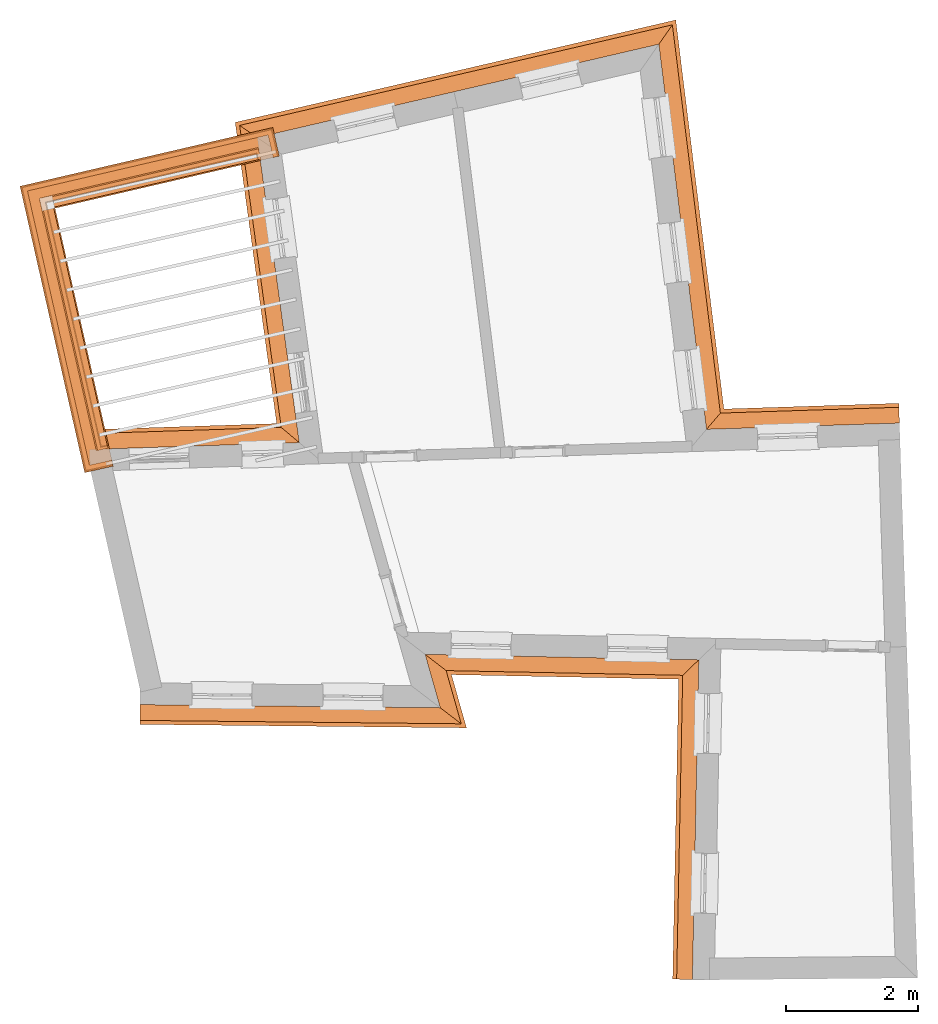
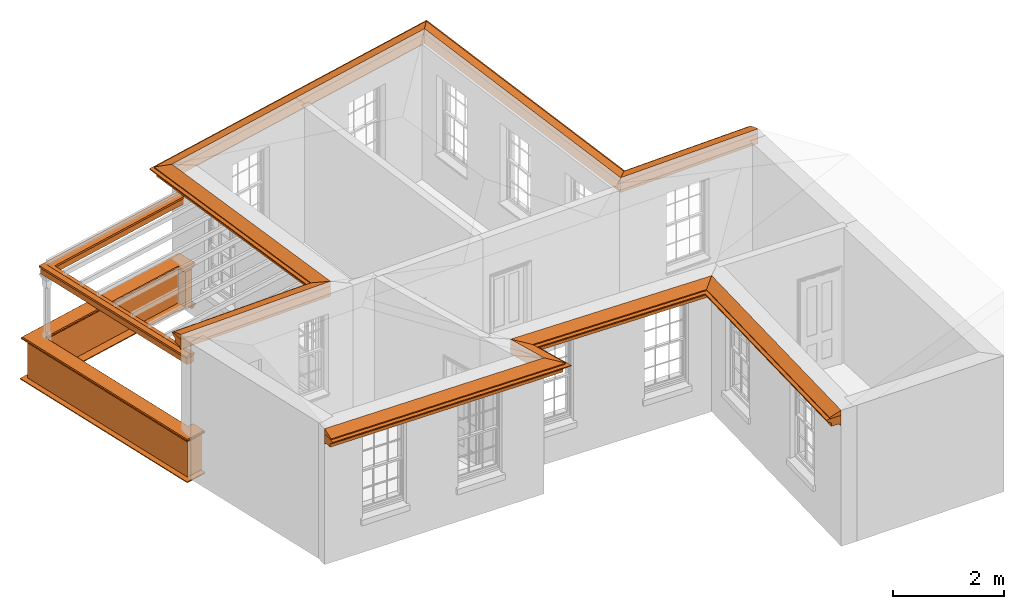
# One storey, part 10 of 11: 9 proxies.
"""IFC2X3 building model written with IfcOpenShell, lengths in metres."""

from ifc_helpers import new_model, entity, si_unit, frame, origin, place, context, subcontext, project, spatial, element, save


model = new_model("IFC2X3")

# Units and contexts
model_context = context("Model", 3, world=origin())
body_context = subcontext(model_context, "Body", "Model", "MODEL_VIEW")
ifc_project = project(units=[si_unit("PLANEANGLEUNIT", "RADIAN"), si_unit("MASSUNIT", "GRAM", prefix="KILO"), si_unit("FORCEUNIT", "NEWTON", prefix="KILO"), si_unit("LENGTHUNIT", "METRE")], contexts=[model_context])

# Site, building, storey
site_placement = place(None, origin())
site = spatial("IfcSite", under=ifc_project, at=site_placement, CompositionType="ELEMENT")
building_placement = place(None, origin())
building = spatial("IfcBuilding", under=site, at=building_placement, Name="Building plot-10", CompositionType="ELEMENT")
storey_placement = place(None, frame((0.0, 0.0, 4.6)))
storey = spatial("IfcBuildingStorey", under=building, at=storey_placement, Name="Floor 1", CompositionType="ELEMENT", Elevation=4.6)

# Proxies
proxy_1_placement = place(storey_placement, frame((0.0, 0.0, 3.0)))
axis2_placement3_d_1 = entity("IfcAxis2Placement3D", entity("IfcCartesianPoint", [0.0, 0.0, 0.0]))
element("IfcBuildingElementProxy", 1, at=proxy_1_placement, inside=storey, Name="eaves", CompositionType="ELEMENT", context=body_context, shape_type="SweptSolid", held_by="IfcProductRepresentation", body=[
    entity("IfcSurfaceCurveSweptAreaSolid", entity("IfcArbitraryClosedProfileDef", "AREA", None, entity("IfcPolyline", [entity("IfcCartesianPoint", [-0.11, 0.25]), entity("IfcCartesianPoint", [-0.33, 0.25]), entity("IfcCartesianPoint", [-0.33, 0.265]), entity("IfcCartesianPoint", [-0.318, 0.268]), entity("IfcCartesianPoint", [-0.309, 0.274]), entity("IfcCartesianPoint", [-0.303, 0.283]), entity("IfcCartesianPoint", [-0.3, 0.295]), entity("IfcCartesianPoint", [-0.285, 0.295]), entity("IfcCartesianPoint", [-0.285, 0.455]), entity("IfcCartesianPoint", [-0.205, 0.455]), entity("IfcCartesianPoint", [-0.205, 0.47]), entity("IfcCartesianPoint", [-0.19, 0.47]), entity("IfcCartesianPoint", [-0.189, 0.483]), entity("IfcCartesianPoint", [-0.186, 0.494]), entity("IfcCartesianPoint", [-0.179, 0.506]), entity("IfcCartesianPoint", [-0.17, 0.514]), entity("IfcCartesianPoint", [-0.16, 0.52]), entity("IfcCartesianPoint", [-0.149, 0.529]), entity("IfcCartesianPoint", [-0.143, 0.539]), entity("IfcCartesianPoint", [-0.14, 0.55]), entity("IfcCartesianPoint", [-0.12, 0.55]), entity("IfcCartesianPoint", [-0.11, 0.48]), entity("IfcCartesianPoint", [-0.11, 0.25])])), axis2_placement3_d_1, entity("IfcPolyline", [entity("IfcCartesianPoint", [42.2025412159909, 16.5029528697415]), entity("IfcCartesianPoint", [46.417501549058, 16.4585722214546]), entity("IfcCartesianPoint", [46.1870677663314, 17.2713951315665]), entity("IfcCartesianPoint", [50.9238235158592, 17.1770031829348]), entity("IfcCartesianPoint", [50.8222805958714, 12.0813989810033])]), 0.0, 1.0, entity("IfcPlane", axis2_placement3_d_1)),
])
proxy_2_placement = place(storey_placement, frame((0.0, 0.0, 3.0)))
axis2_placement3_d_2 = entity("IfcAxis2Placement3D", entity("IfcCartesianPoint", [0.0, 0.0, 0.0]))
element("IfcBuildingElementProxy", 2, at=proxy_2_placement, inside=storey, Name="eaves", CompositionType="ELEMENT", context=body_context, shape_type="SweptSolid", held_by="IfcProductRepresentation", body=[
    entity("IfcSurfaceCurveSweptAreaSolid", entity("IfcArbitraryClosedProfileDef", "AREA", None, entity("IfcPolyline", [entity("IfcCartesianPoint", [-0.11, 0.25]), entity("IfcCartesianPoint", [-0.11, 0.48]), entity("IfcCartesianPoint", [-0.08, 0.49]), entity("IfcCartesianPoint", [0.0, 0.25]), entity("IfcCartesianPoint", [-0.11, 0.25])])), axis2_placement3_d_2, entity("IfcPolyline", [entity("IfcCartesianPoint", [42.2025412159909, 16.5029528697415]), entity("IfcCartesianPoint", [46.417501549058, 16.4585722214546]), entity("IfcCartesianPoint", [46.1870677663314, 17.2713951315665]), entity("IfcCartesianPoint", [50.9238235158592, 17.1770031829348]), entity("IfcCartesianPoint", [50.8222805958714, 12.0813989810033])]), 0.0, 1.0, entity("IfcPlane", axis2_placement3_d_2)),
])
proxy_3_placement = place(storey_placement, frame((0.0, 0.0, 3.0)))
axis2_placement3_d_3 = entity("IfcAxis2Placement3D", entity("IfcCartesianPoint", [0.0, 0.0, 0.0]))
element("IfcBuildingElementProxy", 3, at=proxy_3_placement, inside=storey, Name="eaves", CompositionType="ELEMENT", context=body_context, shape_type="SweptSolid", held_by="IfcProductRepresentation", body=[
    entity("IfcSurfaceCurveSweptAreaSolid", entity("IfcArbitraryClosedProfileDef", "AREA", None, entity("IfcPolyline", [entity("IfcCartesianPoint", [-0.11, 0.25]), entity("IfcCartesianPoint", [-0.33, 0.25]), entity("IfcCartesianPoint", [-0.33, 0.265]), entity("IfcCartesianPoint", [-0.318, 0.268]), entity("IfcCartesianPoint", [-0.309, 0.274]), entity("IfcCartesianPoint", [-0.303, 0.283]), entity("IfcCartesianPoint", [-0.3, 0.295]), entity("IfcCartesianPoint", [-0.285, 0.295]), entity("IfcCartesianPoint", [-0.285, 0.455]), entity("IfcCartesianPoint", [-0.205, 0.455]), entity("IfcCartesianPoint", [-0.205, 0.47]), entity("IfcCartesianPoint", [-0.19, 0.47]), entity("IfcCartesianPoint", [-0.189, 0.483]), entity("IfcCartesianPoint", [-0.186, 0.494]), entity("IfcCartesianPoint", [-0.179, 0.506]), entity("IfcCartesianPoint", [-0.17, 0.514]), entity("IfcCartesianPoint", [-0.16, 0.52]), entity("IfcCartesianPoint", [-0.149, 0.529]), entity("IfcCartesianPoint", [-0.143, 0.539]), entity("IfcCartesianPoint", [-0.14, 0.55]), entity("IfcCartesianPoint", [-0.12, 0.55]), entity("IfcCartesianPoint", [-0.11, 0.48]), entity("IfcCartesianPoint", [-0.11, 0.25])])), axis2_placement3_d_3, entity("IfcPolyline", [entity("IfcCartesianPoint", [53.7171883232646, 20.2693920877442]), entity("IfcCartesianPoint", [50.5642739162713, 20.1666742949917]), entity("IfcCartesianPoint", [49.848379831915, 25.9545222153713]), entity("IfcCartesianPoint", [44.2553130901615, 24.6549958253689]), entity("IfcCartesianPoint", [44.899349589373, 19.9821185323366]), entity("IfcCartesianPoint", [41.4398986189341, 19.8694141826623])]), 0.0, 1.0, entity("IfcPlane", axis2_placement3_d_3)),
])
proxy_4_placement = place(storey_placement, frame((0.0, 0.0, 3.0)))
axis2_placement3_d_4 = entity("IfcAxis2Placement3D", entity("IfcCartesianPoint", [0.0, 0.0, 0.0]))
element("IfcBuildingElementProxy", 4, at=proxy_4_placement, inside=storey, Name="eaves", CompositionType="ELEMENT", context=body_context, shape_type="SweptSolid", held_by="IfcProductRepresentation", body=[
    entity("IfcSurfaceCurveSweptAreaSolid", entity("IfcArbitraryClosedProfileDef", "AREA", None, entity("IfcPolyline", [entity("IfcCartesianPoint", [-0.11, 0.25]), entity("IfcCartesianPoint", [-0.11, 0.48]), entity("IfcCartesianPoint", [-0.08, 0.49]), entity("IfcCartesianPoint", [0.0, 0.25]), entity("IfcCartesianPoint", [-0.11, 0.25])])), axis2_placement3_d_4, entity("IfcPolyline", [entity("IfcCartesianPoint", [53.7171883232646, 20.2693920877442]), entity("IfcCartesianPoint", [50.5642739162713, 20.1666742949917]), entity("IfcCartesianPoint", [49.848379831915, 25.9545222153713]), entity("IfcCartesianPoint", [44.2553130901615, 24.6549958253689]), entity("IfcCartesianPoint", [44.899349589373, 19.9821185323366]), entity("IfcCartesianPoint", [41.4398986189341, 19.8694141826623])]), 0.0, 1.0, entity("IfcPlane", axis2_placement3_d_4)),
])
proxy_5_placement = place(storey_placement, origin())
axis2_placement3_d_5 = entity("IfcAxis2Placement3D", entity("IfcCartesianPoint", [0.0, 0.0, 0.0]))
element("IfcBuildingElementProxy", 5, at=proxy_5_placement, inside=storey, Name="parapet", CompositionType="ELEMENT", context=body_context, shape_type="SweptSolid", held_by="IfcProductRepresentation", body=[
    entity("IfcSurfaceCurveSweptAreaSolid", entity("IfcArbitraryClosedProfileDef", "AREA", None, entity("IfcPolyline", [entity("IfcCartesianPoint", [0.0, 0.25]), entity("IfcCartesianPoint", [0.795, 0.25]), entity("IfcCartesianPoint", [0.795, 0.09]), entity("IfcCartesianPoint", [0.02, 0.09]), entity("IfcCartesianPoint", [0.02, -0.08]), entity("IfcCartesianPoint", [0.0, -0.08]), entity("IfcCartesianPoint", [0.0, 0.25])])), axis2_placement3_d_5, entity("IfcPolyline", [entity("IfcCartesianPoint", [43.9759882125727, 24.4874320680703]), entity("IfcCartesianPoint", [43.9533564717587, 24.5848374288454]), entity("IfcCartesianPoint", [40.7924789671052, 23.8504203509661]), entity("IfcCartesianPoint", [41.6214715425967, 20.1799381643258]), entity("IfcCartesianPoint", [41.7190146491214, 20.201968651599])]), 0.0, 1.0, entity("IfcPlane", axis2_placement3_d_5)),
])
proxy_6_placement = place(storey_placement, origin())
axis2_placement3_d_6 = entity("IfcAxis2Placement3D", entity("IfcCartesianPoint", [0.0, 0.0, 0.0]))
element("IfcBuildingElementProxy", 6, at=proxy_6_placement, inside=storey, Name="parapet", CompositionType="ELEMENT", context=body_context, shape_type="SweptSolid", held_by="IfcProductRepresentation", body=[
    entity("IfcSurfaceCurveSweptAreaSolid", entity("IfcArbitraryClosedProfileDef", "AREA", None, entity("IfcPolyline", [entity("IfcCartesianPoint", [0.795, 0.265]), entity("IfcCartesianPoint", [0.807, 0.268]), entity("IfcCartesianPoint", [0.816, 0.274]), entity("IfcCartesianPoint", [0.822, 0.283]), entity("IfcCartesianPoint", [0.825, 0.295]), entity("IfcCartesianPoint", [0.84, 0.295]), entity("IfcCartesianPoint", [0.84, 0.305]), entity("IfcCartesianPoint", [0.842, 0.317]), entity("IfcCartesianPoint", [0.849, 0.326]), entity("IfcCartesianPoint", [0.858, 0.333]), entity("IfcCartesianPoint", [0.87, 0.335]), entity("IfcCartesianPoint", [0.882, 0.333]), entity("IfcCartesianPoint", [0.891, 0.326]), entity("IfcCartesianPoint", [0.898, 0.317]), entity("IfcCartesianPoint", [0.9, 0.305]), entity("IfcCartesianPoint", [0.9, 0.035]), entity("IfcCartesianPoint", [0.898, 0.023]), entity("IfcCartesianPoint", [0.891, 0.014]), entity("IfcCartesianPoint", [0.882, 0.007]), entity("IfcCartesianPoint", [0.87, 0.005]), entity("IfcCartesianPoint", [0.858, 0.007]), entity("IfcCartesianPoint", [0.849, 0.014]), entity("IfcCartesianPoint", [0.842, 0.023]), entity("IfcCartesianPoint", [0.84, 0.035]), entity("IfcCartesianPoint", [0.84, 0.045]), entity("IfcCartesianPoint", [0.825, 0.045]), entity("IfcCartesianPoint", [0.822, 0.057]), entity("IfcCartesianPoint", [0.816, 0.066]), entity("IfcCartesianPoint", [0.807, 0.072]), entity("IfcCartesianPoint", [0.795, 0.075]), entity("IfcCartesianPoint", [0.795, 0.265])])), axis2_placement3_d_6, entity("IfcPolyline", [entity("IfcCartesianPoint", [43.9759882125727, 24.4874320680703]), entity("IfcCartesianPoint", [43.9533564717587, 24.5848374288454]), entity("IfcCartesianPoint", [40.7924789671052, 23.8504203509661]), entity("IfcCartesianPoint", [41.6214715425967, 20.1799381643258]), entity("IfcCartesianPoint", [41.7190146491214, 20.201968651599])]), 0.0, 1.0, entity("IfcPlane", axis2_placement3_d_6)),
])
proxy_7_placement = place(storey_placement, origin())
axis2_placement3_d_7 = entity("IfcAxis2Placement3D", entity("IfcCartesianPoint", [0.0, 0.0, 0.0]))
element("IfcBuildingElementProxy", 7, at=proxy_7_placement, inside=storey, Name="parapet", CompositionType="ELEMENT", context=body_context, shape_type="SweptSolid", held_by="IfcProductRepresentation", body=[
    entity("IfcSurfaceCurveSweptAreaSolid", entity("IfcArbitraryClosedProfileDef", "AREA", None, entity("IfcPolyline", [entity("IfcCartesianPoint", [-0.1, 0.25]), entity("IfcCartesianPoint", [-0.1, 0.265]), entity("IfcCartesianPoint", [-0.085, 0.265]), entity("IfcCartesianPoint", [-0.084, 0.278]), entity("IfcCartesianPoint", [-0.081, 0.289]), entity("IfcCartesianPoint", [-0.074, 0.301]), entity("IfcCartesianPoint", [-0.065, 0.309]), entity("IfcCartesianPoint", [-0.055, 0.315]), entity("IfcCartesianPoint", [-0.044, 0.324]), entity("IfcCartesianPoint", [-0.038, 0.334]), entity("IfcCartesianPoint", [-0.035, 0.345]), entity("IfcCartesianPoint", [-0.015, 0.345]), entity("IfcCartesianPoint", [0.0, 0.25]), entity("IfcCartesianPoint", [-0.1, 0.25])])), axis2_placement3_d_7, entity("IfcPolyline", [entity("IfcCartesianPoint", [43.9759882125727, 24.4874320680703]), entity("IfcCartesianPoint", [43.9533564717587, 24.5848374288454]), entity("IfcCartesianPoint", [40.7924789671052, 23.8504203509661]), entity("IfcCartesianPoint", [41.6214715425967, 20.1799381643258]), entity("IfcCartesianPoint", [41.7190146491214, 20.201968651599])]), 0.0, 1.0, entity("IfcPlane", axis2_placement3_d_7)),
])
proxy_8_placement = place(storey_placement, frame((0.0, 0.0, 3.0)))
axis2_placement3_d_8 = entity("IfcAxis2Placement3D", entity("IfcCartesianPoint", [0.0, 0.0, 0.0]))
element("IfcBuildingElementProxy", 8, at=proxy_8_placement, inside=storey, Name="pergola beam", CompositionType="ELEMENT", context=body_context, shape_type="SweptSolid", held_by="IfcProductRepresentation", body=[
    entity("IfcSurfaceCurveSweptAreaSolid", entity("IfcArbitraryClosedProfileDef", "AREA", None, entity("IfcPolyline", [entity("IfcCartesianPoint", [-0.7, -0.08]), entity("IfcCartesianPoint", [-0.7, 0.08]), entity("IfcCartesianPoint", [-0.56, 0.08]), entity("IfcCartesianPoint", [-0.56, -0.08]), entity("IfcCartesianPoint", [-0.7, -0.08])])), axis2_placement3_d_8, entity("IfcPolyline", [entity("IfcCartesianPoint", [44.0117996882238, 24.5984164733338]), entity("IfcCartesianPoint", [40.7924789671052, 23.8504203509661]), entity("IfcCartesianPoint", [41.6346898349606, 20.1214123004109])]), 0.0, 1.0, entity("IfcPlane", axis2_placement3_d_8)),
])
proxy_9_placement = place(storey_placement, frame((0.0, 0.0, 3.0)))
axis2_placement3_d_9 = entity("IfcAxis2Placement3D", entity("IfcCartesianPoint", [0.0, 0.0, 0.0]))
element("IfcBuildingElementProxy", 9, at=proxy_9_placement, inside=storey, Name="pergola beam", CompositionType="ELEMENT", context=body_context, shape_type="SweptSolid", held_by="IfcProductRepresentation", body=[
    entity("IfcSurfaceCurveSweptAreaSolid", entity("IfcArbitraryClosedProfileDef", "AREA", None, entity("IfcPolyline", [entity("IfcCartesianPoint", [-0.5, 0.0]), entity("IfcCartesianPoint", [-0.52, -0.1]), entity("IfcCartesianPoint", [-0.56, -0.1]), entity("IfcCartesianPoint", [-0.56, 0.1]), entity("IfcCartesianPoint", [-0.52, 0.1]), entity("IfcCartesianPoint", [-0.5, 0.0])])), axis2_placement3_d_9, entity("IfcPolyline", [entity("IfcCartesianPoint", [44.0117996882238, 24.5984164733338]), entity("IfcCartesianPoint", [40.7924789671052, 23.8504203509661]), entity("IfcCartesianPoint", [41.6346898349606, 20.1214123004109])]), 0.0, 1.0, entity("IfcPlane", axis2_placement3_d_9)),
])

save(model, "model.ifc")
